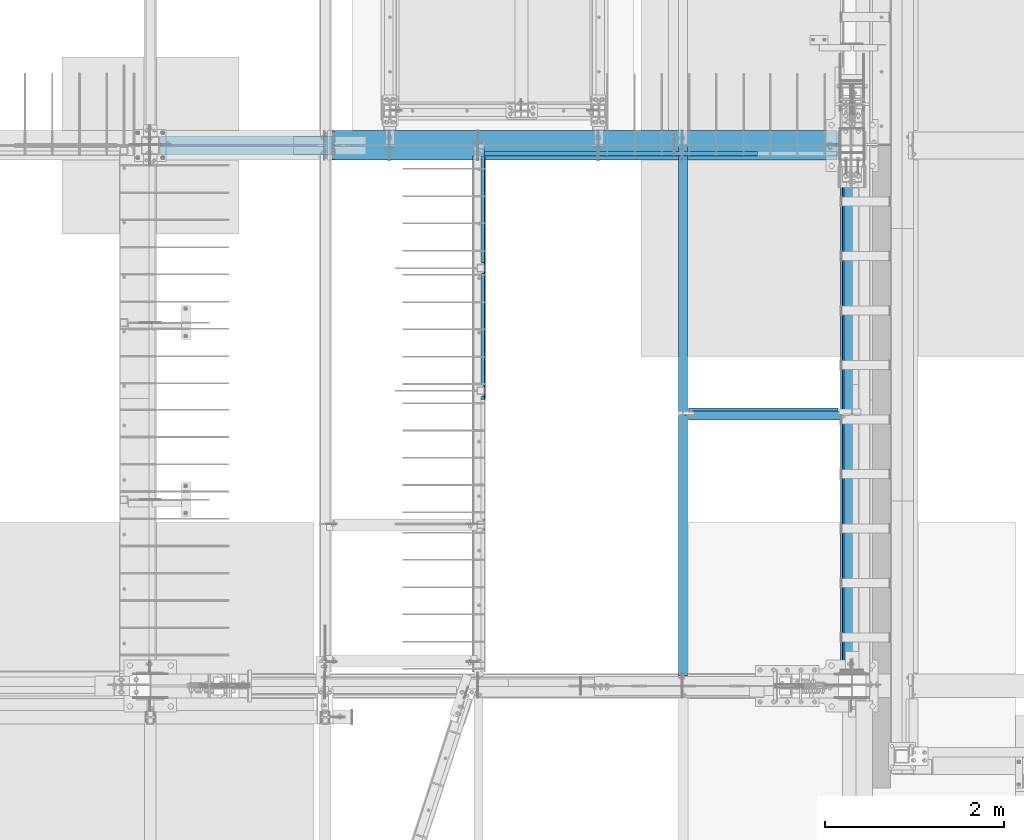
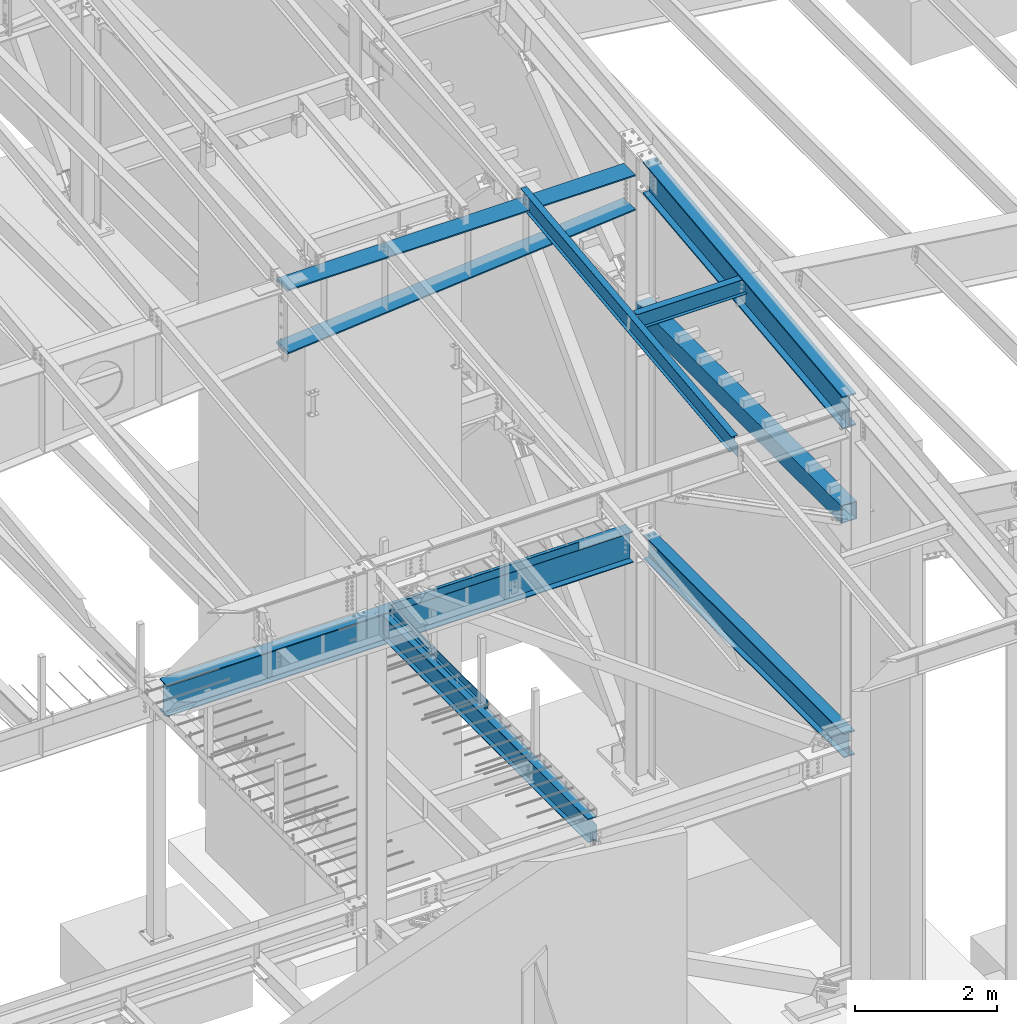
# One storey, part 720 of 1179: 11 beams, 8 elements without a shape of their own.
"""IFC2X3 building model written with IfcOpenShell, lengths in millimetres."""

import ifcopenshell
import ifcopenshell.guid

model = None  # the IFC model being written
_history = None  # IfcOwnerHistory: only IFC2X3 demands one
_inside = {}  # id of a spatial element -> (the spatial element, [elements in it])
_under = {}  # id of a project, library or spatial element -> (it, [spatial elements below it])
_declared = {}  # id of a project -> (the project, [libraries it declares])
_typed = {}  # id of a type object -> (the type object, [elements of that type])
_made_of = {}  # id of a material, layer set ... -> (it, [elements and type objects made of it])


def new_model(schema):
    """Start an empty IFC model of exactly this schema.

    Asked for "IFC4X3", IfcOpenShell would pick the latest addendum, in which some entities
    have other attributes; the version numbers below select the first issue.
    IFC2X3 requires an IfcOwnerHistory on every rooted entity: one is made here for all.
    """
    global model, _history
    if schema == "IFC4X3":
        model = ifcopenshell.file(schema_version=(4, 3, 0, 0))
    else:
        model = ifcopenshell.file(schema=schema)
    _inside.clear()
    _under.clear()
    _declared.clear()
    _typed.clear()
    _made_of.clear()
    _history = None
    if model.schema == "IFC2X3":
        org = make("IfcOrganization", Name="unknown")
        user = make(
            "IfcPersonAndOrganization",
            ThePerson=make("IfcPerson", FamilyName="unknown"),
            TheOrganization=org,
        )
        app = make(
            "IfcApplication",
            ApplicationDeveloper=org,
            Version="unknown",
            ApplicationFullName="unknown",
            ApplicationIdentifier="unknown",
        )
        _history = make(
            "IfcOwnerHistory",
            OwningUser=user,
            OwningApplication=app,
            ChangeAction="ADDED",
            CreationDate=0,
        )
    return model


def make(cls, **values):
    """One entity of the class cls with the attributes given. An attribute that is None is left unset."""
    return model.create_entity(
        cls, **{name: value for name, value in values.items() if value is not None}
    )


def rooted(cls, **values):
    """An entity with a GlobalId (a new one), such as an element, a storey or a relation."""
    return make(cls, GlobalId=ifcopenshell.guid.new(), OwnerHistory=_history, **values)


def si_unit(unit_type, name, prefix=None):
    """IfcSIUnit, for example si_unit("LENGTHUNIT", "METRE", prefix="MILLI")."""
    return make("IfcSIUnit", UnitType=unit_type, Prefix=prefix, Name=name)


def assignment(units):
    """IfcUnitAssignment: the units of a project."""
    return None if units is None else make("IfcUnitAssignment", Units=units)


def point(xyz):
    """IfcCartesianPoint."""
    return None if xyz is None else make("IfcCartesianPoint", Coordinates=xyz)


def direction(xyz):
    """IfcDirection."""
    return None if xyz is None else make("IfcDirection", DirectionRatios=xyz)


def frame(location, z_axis=None, x_axis=None):
    """IfcAxis2Placement3D, a coordinate frame: its origin and axes. An axis left out is left unset."""
    return make(
        "IfcAxis2Placement3D",
        Location=point(location),
        Axis=direction(z_axis),
        RefDirection=direction(x_axis),
    )


def origin_with_axes():
    """The frame at (0, 0, 0) with the z axis (0, 0, 1) and the x axis (1, 0, 0) written out."""
    return frame((0.0, 0.0, 0.0), z_axis=(0.0, 0.0, 1.0), x_axis=(1.0, 0.0, 0.0))


def place(relative_to, where):
    """IfcLocalPlacement: puts the frame where relative to a parent placement (None: the world)."""
    return make(
        "IfcLocalPlacement", PlacementRelTo=relative_to, RelativePlacement=where
    )


def context(
    kind, dimensions, precision=None, world=None, true_north=None, identifier=None
):
    """IfcGeometricRepresentationContext, for example the 3D "Model" context."""
    return make(
        "IfcGeometricRepresentationContext",
        ContextIdentifier=identifier,
        ContextType=kind,
        CoordinateSpaceDimension=dimensions,
        Precision=precision,
        WorldCoordinateSystem=world,
        TrueNorth=true_north,
    )


def subcontext(parent, identifier, kind, view, scale=None):
    """IfcGeometricRepresentationSubContext, for example "Body" below "Model"."""
    return make(
        "IfcGeometricRepresentationSubContext",
        ContextIdentifier=identifier,
        ContextType=kind,
        ParentContext=parent,
        TargetScale=scale,
        TargetView=view,
    )


def project(units=None, contexts=None):
    """IfcProject with its units and contexts."""
    return rooted(
        "IfcProject",
        Name="project",
        RepresentationContexts=contexts,
        UnitsInContext=assignment(units),
    )


def spatial(cls, under=None, at=None, **own):
    """A site, building, storey or space (cls), placed at a placement, below another one or the project."""
    s = rooted(cls, ObjectPlacement=at, **own)
    if under is not None:
        _under.setdefault(under.id(), (under, []))[1].append(s)
    return s


def faces_of(points, faces, orient=None, outer=None):
    """IfcFace entities. A face is a list of loops; a loop is a list of indices into points, from 0.

    orient and outer hold one flag for each loop. By default every Orientation is true, the
    first loop of a face is its IfcFaceOuterBound and the others are IfcFaceBound.
    """
    made = []
    for i, loops in enumerate(faces):
        bounds = []
        for j, loop in enumerate(loops):
            is_outer = j == 0 if outer is None else outer[i][j]
            bounds.append(
                make(
                    "IfcFaceOuterBound" if is_outer else "IfcFaceBound",
                    Bound=make("IfcPolyLoop", Polygon=[points[k] for k in loop]),
                    Orientation=True if orient is None else orient[i][j],
                )
            )
        made.append(make("IfcFace", Bounds=bounds))
    return made


def faceted_brep(points, faces, orient=None, outer=None, voids=None):
    """IfcFacetedBrep: a solid bounded by flat faces; with voids (closed shells), ...WithVoids."""
    shared = [point(p) for p in points]
    hull = make("IfcClosedShell", CfsFaces=faces_of(shared, faces, orient, outer))
    if voids is None:
        return make("IfcFacetedBrep", Outer=hull)
    return make(
        "IfcFacetedBrepWithVoids",
        Outer=hull,
        Voids=[
            make(cls, CfsFaces=faces_of(shared, fs, o, b)) for cls, fs, o, b in voids
        ],
    )


def shape(context_of_items, identifier, shape_type, items):
    """IfcShapeRepresentation: the items that make up one representation, for example the "Body"."""
    return make(
        "IfcShapeRepresentation",
        ContextOfItems=context_of_items,
        RepresentationIdentifier=identifier,
        RepresentationType=shape_type,
        Items=items,
    )


def material(Name=None, Category=None):
    """IfcMaterial."""
    return make("IfcMaterial", Name=Name, Category=Category)


def made_of(thing, what):
    """Note that an element or type object is made of a material, layer set ...; save() writes the relation."""
    if what is not None:
        _made_of.setdefault(what.id(), (what, []))[1].append(thing)
    return thing


def type_object(cls, material=None, **own):
    """A type object (cls), such as IfcWallType, which elements share."""
    return made_of(rooted(cls, **own), material)


def element(
    cls,
    number,
    at=None,
    inside=None,
    cuts=None,
    type_object=None,
    material=None,
    context=None,
    identifier="Body",
    shape_type=None,
    held_by="IfcProductDefinitionShape",
    body=None,
    shapes=None,
    **own,
):
    """One element of the class cls, such as IfcWall. Its Tag is "e" and its number.

    at: its placement. inside: the storey or other place that contains it. cuts: it is an
    opening in that element (IfcRelVoidsElement). A single representation is given by context,
    identifier, shape_type and body (its items); several are given by shapes. held_by: the class
    of the entity that holds the representations. save() writes the other relations.
    """
    e = rooted(cls, Tag="e%d" % number, ObjectPlacement=at, **own)
    if body is not None:
        shapes = [shape(context, identifier, shape_type, body)]
    if shapes is not None:
        e.Representation = make(held_by, Representations=shapes)
    if inside is not None:
        _inside.setdefault(inside.id(), (inside, []))[1].append(e)
    if cuts is not None:
        rooted(
            "IfcRelVoidsElement", RelatingBuildingElement=cuts, RelatedOpeningElement=e
        )
    if type_object is not None:
        _typed.setdefault(type_object.id(), (type_object, []))[1].append(e)
    return made_of(e, material)


def aggregate(whole, parts):
    """IfcRelAggregates: a whole, such as a stair, and the parts it consists of."""
    return rooted("IfcRelAggregates", RelatingObject=whole, RelatedObjects=parts)


def save(model, path):
    """Write the relations noted so far, then the file.

    IfcRelAggregates (storeys below a building ...), IfcRelContainedInSpatialStructure (elements
    in a storey), IfcRelDefinesByType, IfcRelAssociatesMaterial and IfcRelDeclares: one each for
    every whole, place, type object, material and project.
    """
    for whole, parts in _under.values():
        aggregate(whole, parts)
    for where, things in _inside.values():
        rooted(
            "IfcRelContainedInSpatialStructure",
            RelatedElements=things,
            RelatingStructure=where,
        )
    for kind, things in _typed.values():
        rooted("IfcRelDefinesByType", RelatedObjects=things, RelatingType=kind)
    for what, things in _made_of.values():
        rooted("IfcRelAssociatesMaterial", RelatedObjects=things, RelatingMaterial=what)
    for by, libraries in _declared.values():
        rooted("IfcRelDeclares", RelatingContext=by, RelatedDefinitions=libraries)
    model.write(path)


model = new_model("IFC2X3")

# Units and contexts
model_context = context("Model", 3, precision=1e-05, world=origin_with_axes())
body_context = subcontext(model_context, "Body", "Model", "MODEL_VIEW")
ifc_project = project(units=[si_unit("LENGTHUNIT", "METRE", prefix="MILLI"), si_unit("AREAUNIT", "SQUARE_METRE"), si_unit("VOLUMEUNIT", "CUBIC_METRE"), si_unit("MASSUNIT", "GRAM", prefix="KILO"), si_unit("TIMEUNIT", "SECOND"), si_unit("PLANEANGLEUNIT", "RADIAN"), si_unit("SOLIDANGLEUNIT", "STERADIAN"), si_unit("THERMODYNAMICTEMPERATUREUNIT", "DEGREE_CELSIUS"), si_unit("LUMINOUSINTENSITYUNIT", "LUMEN")], contexts=[model_context])

# Site, building, storey
site_placement = place(None, origin_with_axes())
site = spatial("IfcSite", under=ifc_project, at=site_placement, CompositionType="ELEMENT")
building_placement = place(site_placement, origin_with_axes())
building = spatial("IfcBuilding", under=site, at=building_placement, Name="Undefined", CompositionType="ELEMENT")
storey_placement = place(building_placement, origin_with_axes())
storey = spatial("IfcBuildingStorey", under=building, at=storey_placement, Name="Undefined", CompositionType="ELEMENT", Elevation=0.0)

# Assembly, beam
assembly_1_placement = place(storey_placement, origin_with_axes())
assembly_1 = element("IfcElementAssembly", 1, at=assembly_1_placement, inside=storey, Name="BEAM", AssemblyPlace="NOTDEFINED", PredefinedType="RIGID_FRAME")
ifc_material_1 = material(Name="STEEL/A36")
beam_type_1 = type_object("IfcBeamType", PredefinedType="NOTDEFINED")
beam_1_placement = place(assembly_1_placement, frame((21723.35, 11366.5, 4235.45000610352), z_axis=(1.0, 0.0, 0.0), x_axis=(0.0, 0.0, -1.0)))
beam_1 = element("IfcBeam", 2, at=beam_1_placement, type_object=beam_type_1, material=ifc_material_1, Name="BENT_PLATE", context=body_context, shape_type="Brep", body=[
    faceted_brep([(0.0, -3.17499999999927, -1524.0), (6.00266503170133e-10, -3.17499999922438, 1524.00000000052), (6.00266503170133e-10, 3.17500000077416, 1524.00000000052), (0.0, 3.17499999999927, -1524.0), (127.000006103516, 3.17499999999927, 1524.0), (127.000006103516, 3.17499999999927, -1524.0), (133.350006103517, -3.17499999999927, -1524.0), (133.350006103517, -3.17499999999927, 1524.0), (127.000006103516, 47.6249992370613, 1524.0), (127.000006103516, 47.6249992370613, -1524.0), (133.350006103517, 47.6249992370613, 1524.0), (133.350006103517, 47.6249992370613, -1524.0)], [[[0, 1, 2, 3]], [[3, 2, 4, 5]], [[1, 0, 6, 7]], [[5, 4, 8, 9]], [[4, 2, 1, 7, 10, 8]], [[7, 6, 11, 10]], [[6, 0, 3, 5, 9, 11]], [[10, 11, 9, 8]]]),
])

assembly_2_placement = place(storey_placement, origin_with_axes())
assembly_2 = element("IfcElementAssembly", 3, at=assembly_2_placement, inside=storey, Name="BEAM", AssemblyPlace="NOTDEFINED", PredefinedType="RIGID_FRAME")
ifc_material_2 = material(Name="STEEL/A992")
beam_type_2 = type_object("IfcBeamType", Name="W12X14", PredefinedType="NOTDEFINED")
beam_2_placement = place(assembly_2_placement, frame((22415.5000835348, 8475.14317923319, 10052.7877808976), z_axis=(0.0, -0.112284087038017, 0.993676146336441), x_axis=(0.999999999988899, -4.71199999952473e-06, 0.0)))
beam_2 = element("IfcBeam", 4, at=beam_2_placement, type_object=beam_type_2, material=ifc_material_2, Name="BEAM", ObjectType="W12X14", context=body_context, shape_type="Brep", body=[
    faceted_brep([(1770.85649904564, -50.7999999986041, 150.812499999789), (1770.85649904565, -50.7999999986059, 144.46249999979), (1770.85649904561, -2.381249998567, 144.462499999787), (1770.8564990458, -2.38124999857428, 125.412499806802), (1770.85649904581, 2.38167736519972, 125.412499806804), (1770.85649904561, 2.38125000143555, 144.462499999785), (1770.85649904557, 50.8000000014763, 144.462499999781), (1770.85649904556, 50.8000000014781, 150.81249999978), (1771.82322896839, -2.3812499985761, 120.552420288775), (1771.8232289684, 2.38163594190701, 120.552420288775), (1774.57624286887, -2.38124999857428, 116.432243820635), (1774.57624286888, 2.38160097677792, 116.432243820636), (1778.69641933703, -2.38124999857246, 113.679229920166), (1778.69641933704, 2.38157779293761, 113.679229920168), (1783.55649885508, -2.38124999857064, 112.712499997577), (1783.55649885509, 2.38156991991491, 112.712499997579), (1872.45624059635, -2.3812499984997, 112.712499997355), (1872.45621725151, 2.38125000150285, 112.712499997353), (62.7059974723888, -50.7999999999302, 150.81249999994), (62.7059974723124, 50.8000000001521, 150.812499999931), (62.7059974723197, 50.8000000001484, 144.462499999931), (62.7059974723561, 2.3812500001095, 144.462499999934), (62.7059974721487, 2.38161408837368, 138.112499807496), (62.7059974721342, -2.38124999989668, 138.112499807496), (62.7059974723597, -2.38124999989304, 144.462499999938), (62.7059974723961, -50.799999999932, 144.462499999941), (61.7392675495539, 2.38157202631191, 133.252420289446), (61.7392675495394, -2.3812499998985, 133.252420289446), (58.9862536490546, 2.38153636781681, 129.132243821286), (58.9862536490436, -2.38124999990396, 129.132243821286), (54.8660771808754, 2.38151254157128, 126.379229920809), (54.8660771808609, -2.3812499999076, 126.379229920805), (50.0059976628036, 2.38150417490215, 125.412499998221), (50.005997662789, -2.38124999991123, 125.412499998223), (15.0812242587599, 2.38125000006403, 125.412499998332), (15.0812476035971, -2.38124999993852, 125.412499998332), (15.0810853273215, 2.38124999996217, -125.412500001446), (15.0811086721551, -2.38125000003856, -125.412500001445), (50.0059976626144, 2.37934495275113, -125.41250000147), (50.0059976626035, -2.3812500000131, -125.412500001472), (54.8660771806644, 2.3793365119891, -126.379229924058), (54.8660771806535, -2.38125000000946, -126.379229924061), (58.9862536488217, 2.379312566929, -129.132243824528), (58.9862536488108, -2.38125000000764, -129.13224382453), (61.7392675493029, 2.37927676298568, -133.252420292667), (61.7392675492883, -2.38125000000764, -133.252420292667), (62.7059974718941, 2.37923455098462, -138.112499810695), (62.7059974718795, -2.38125000000946, -138.112499810699), (62.7059974720578, 50.800000000032, -144.462499999951), (62.7059974720978, 2.37627512105973, -144.462499999945), (1732.75606310386, 2.38086597553229, -144.462500000094), (1732.75582577042, 50.800000001329, -144.462500000096), (62.7059974720687, 50.8000000000284, -150.812499999949), (1732.75582225317, 50.8000000013253, -150.812500000095), (1732.7560595773, 2.38425295571142, -150.812500000089), (1872.45607480283, 2.38125000139917, -144.462500000105), (1872.4560712675, 2.38493773793743, -150.812500000102), (1872.45633196957, -50.7999999986459, -150.812500000098), (62.7059974721487, -50.800000000052, -150.81249999994), (1872.45633548682, -50.7999999986441, -144.4625000001), (62.7059974721378, -50.800000000052, -144.462499999941), (62.7059974720978, -2.38125000001128, -144.462499999945), (1872.45609814766, -2.3812499986052, -144.462500000103)], [[[0, 1, 2, 3, 4, 5, 6, 7]], [[8, 9, 4, 3]], [[10, 11, 9, 8]], [[12, 13, 11, 10]], [[14, 15, 13, 12]], [[16, 17, 15, 14]], [[18, 19, 20, 21, 22, 23, 24, 25]], [[23, 22, 26, 27]], [[27, 26, 28, 29]], [[29, 28, 30, 31]], [[31, 30, 32, 33]], [[33, 32, 34, 35]], [[35, 34, 36, 37]], [[37, 36, 38, 39]], [[39, 38, 40, 41]], [[41, 40, 42, 43]], [[43, 42, 44, 45]], [[45, 44, 46, 47]], [[48, 49, 50, 51]], [[52, 48, 51, 53]], [[50, 54, 53, 51]], [[55, 56, 54, 50]], [[57, 58, 52, 53, 54, 56]], [[57, 59, 60, 58]], [[47, 46, 49, 48, 52, 58, 60, 61]], [[59, 62, 61, 60]], [[12, 10, 8, 3, 2, 24, 23, 27, 29, 31, 33, 35, 37, 39, 41, 43, 45, 47, 61, 62, 16, 14]], [[25, 24, 2, 1]], [[18, 25, 1, 0]], [[19, 18, 0, 7]], [[20, 19, 7, 6]], [[21, 20, 6, 5]], [[55, 50, 49, 46, 44, 42, 40, 38, 36, 34, 32, 30, 28, 26, 22, 21, 5, 4, 9, 11, 13, 15, 17]], [[62, 59, 57, 56, 55, 17, 16]]]),
])
aggregate(assembly_2, [beam_2])

assembly_3_placement = place(storey_placement, origin_with_axes())
assembly_3 = element("IfcElementAssembly", 5, at=assembly_3_placement, inside=storey, Name="BEAM", AssemblyPlace="NOTDEFINED", PredefinedType="RIGID_FRAME")
beam_3_placement = place(assembly_3_placement, frame((22415.5, 5452.5431792468, 9711.23798851528), z_axis=(0.0, -0.112284087038017, 0.993676146336441), x_axis=(0.0, 0.993676146336441, 0.112284087038017)))
beam_3 = element("IfcBeam", 6, at=beam_3_placement, type_object=beam_type_2, material=ifc_material_2, Name="BEAM", ObjectType="W12X14", context=body_context, shape_type="Brep", body=[
    faceted_brep([(5871.37503272929, -2.38124999999854, -144.462500002917), (5871.37503272929, -50.7999999999993, -144.462500002917), (5870.65749114864, -50.7999999999993, -150.812500002912), (5870.65749114864, 50.7999999999993, -150.812500002912), (5871.37503272929, 50.7999999999993, -144.462500002917), (5871.37503272928, 2.38124783346939, -144.462500002968), (5874.19845246322, 2.38122628119891, -119.476191482236), (5874.19845246322, -2.38124999999854, -119.476191482236), (5875.70477851863, 2.38122688934163, -114.755394783042), (5875.70477851863, -2.38124999999854, -114.755394783042), (5878.90301301472, 2.38122737693629, -110.970393360541), (5878.90301301472, -2.38124999999854, -110.970393360541), (5883.30625374162, 2.38122766974266, -108.697419370077), (5883.30625374162, -2.38124999999854, -108.697419370077), (5888.24414721426, 2.38122772319184, -108.282512497075), (5888.24414721426, -2.38124999999854, -108.282512497075), (6045.98095926941, -2.38124999999854, -126.106563095373), (6045.98095929506, 2.38124999999854, -126.10656309827), (6076.55490468175, -50.7999999999993, 144.462499996846), (6077.27244626239, -50.7999999999993, 150.812499996842), (114.228614327105, -50.7999999999993, 150.812499999873), (113.511072746461, -50.7999999999993, 144.462499999876), (6077.27244626239, 50.7999999999993, 150.812499996842), (114.228614327105, 50.7999999999993, 150.812499999873), (6076.55490468175, 50.7999999999993, 144.462499996846), (113.511072746461, 50.7999999999993, 144.462499999876), (6076.55490468175, 2.38124999999854, 144.462499996846), (113.511072746461, 2.38124999999854, 144.462499999876), (136.689207968453, 50.7999999999993, -144.462500000005), (136.689207968449, 50.7999999999993, -150.8125), (136.689200027815, 2.38132415300061, -150.812500000002), (136.689200027785, 2.38117582134146, -144.462500001737), (-15.7107912112788, 2.38134914656257, -150.812499999922), (-14.9932496306401, 2.38124999999854, -144.462499999927), (136.689191329944, -50.7999999999993, -144.462500000003), (136.689199270568, -2.38124999999854, -144.462500000005), (136.689199270599, -2.38117588245223, -150.8125), (136.689191329941, -50.7999999999993, -150.8125), (-14.9932496306401, -2.38124999999854, -144.462499999927), (-15.7107912112788, -2.38115088886843, -150.812499999922), (-14.7278431263294, -2.38124999999854, -142.113742314172), (10.9745586429563, -2.38124999999854, 85.3438094690136), (10.9745586429563, 2.38124999999854, 85.3438094690136), (-14.7278305511045, 2.38124999999854, -142.113631027696), (93.0025247126168, -2.38124999999854, 76.0747580626012), (93.0025247126168, 2.38124999999854, 76.0747580626012), (97.9404181857699, -2.38124999999854, 76.4896649350048), (97.9404181857699, 2.38124999999854, 76.4896649350048), (102.343658913291, -2.38124999999854, 78.7626389252728), (102.343658913291, 2.38124999999854, 78.7626389252728), (105.541893409889, -2.38124999999854, 82.5476403479479), (105.541893409889, 2.38124999999854, 82.5476403479479), (107.048219465527, -2.38124999999854, 87.2684370475545), (107.048219465527, 2.38124999999854, 87.2684370475545), (113.511072746461, -2.38124999999854, 144.462499999876), (6076.55490468175, -2.38124999999854, 144.462499996846)], [[[0, 1, 2, 3, 4, 5, 6, 7]], [[7, 6, 8, 9]], [[9, 8, 10, 11]], [[11, 10, 12, 13]], [[13, 12, 14, 15]], [[16, 15, 14, 17]], [[18, 19, 20, 21]], [[19, 22, 23, 20]], [[22, 24, 25, 23]], [[24, 26, 27, 25]], [[28, 29, 30, 31]], [[31, 30, 32, 33]], [[34, 35, 36, 37]], [[38, 39, 36, 35]], [[40, 41, 42, 43, 33, 32, 39, 38]], [[44, 45, 42, 41]], [[46, 47, 45, 44]], [[48, 49, 47, 46]], [[50, 51, 49, 48]], [[52, 53, 51, 50]], [[20, 23, 25, 27, 53, 52, 54, 21]], [[55, 18, 21, 54]], [[26, 24, 22, 19, 18, 55, 16, 17]], [[12, 10, 8, 6, 5, 31, 33, 43, 42, 45, 47, 49, 51, 53, 27, 26, 17, 14]], [[28, 31, 5, 4]], [[29, 28, 4, 3]], [[37, 36, 39, 32, 30, 29, 3, 2]], [[34, 37, 2, 1]], [[35, 34, 1, 0]], [[55, 54, 52, 50, 48, 46, 44, 41, 40, 38, 35, 0, 7, 9, 11, 13, 15, 16]]]),
])
aggregate(assembly_3, [beam_3])

# Assembly, beams
assembly_4_placement = place(storey_placement, origin_with_axes())
assembly_4 = element("IfcElementAssembly", 7, at=assembly_4_placement, inside=storey, Name="BEAM", AssemblyPlace="NOTDEFINED", PredefinedType="RIGID_FRAME")
beam_type_3 = type_object("IfcBeamType", Name="W16X31", PredefinedType="NOTDEFINED")
beam_4_placement = place(assembly_4_placement, frame((20129.5, 5435.6, 3900.4875), z_axis=(0.0, 0.0, 1.0), x_axis=(0.0, 1.0, 0.0)))
beam_4 = element("IfcBeam", 8, at=beam_4_placement, type_object=beam_type_3, material=ifc_material_2, Name="BEAM", ObjectType="W16X31", context=body_context, shape_type="Brep", body=[
    faceted_brep([(19.84375, -3.17499999999927, -141.2875), (19.84375, 3.17499999999927, -141.2875), (142.081250190735, 3.17517002077875, -141.2875), (142.081250190735, -3.17499999999927, -141.2875), (146.94132970878, 3.17517064521599, -142.254229922588), (146.94132970878, -3.17499999999927, -142.254229922588), (151.061506176934, 3.17517242088434, -145.007243823066), (151.061506176934, -3.17499999999927, -145.007243823066), (153.814520077412, 3.17517507744924, -149.12742029122), (153.814520077412, -3.17499999999927, -149.12742029122), (154.78125, -3.17499999999927, -153.987499809266), (154.78125, 3.17517821047295, -153.987499809266), (154.780750000001, 3.17549991607666, -190.5), (154.780750000001, 3.17549991607666, -201.6125), (154.78125, -69.8499999999985, -201.6125), (154.78125, -69.8499999999985, -190.5), (154.78125, -3.17499999999927, -190.5), (5900.73750167641, 69.8499999985015, -190.5), (5900.73750167641, 69.8499999985015, -201.6125), (154.780750000001, 69.8499999999985, -201.6125), (154.780750000001, 69.8499999999985, -190.5), (5900.73750007622, 3.17499999850133, -190.5), (5900.73749999986, 3.17549991607666, -201.6125), (6027.73750007621, 3.17499999846859, -190.5), (6027.7375, 3.17549991607666, -201.6125), (5927.72500167648, 69.8499999984942, 190.5), (5927.72500167647, 3.17499999849406, 190.5), (154.78125, 3.17499999999927, 190.5), (154.78125, 69.8499999999985, 190.5), (142.081250190735, -3.17499999999927, 163.5125), (142.081250190735, 3.17497498411103, 163.5125), (19.84375, 3.17499999999927, 163.5125), (19.84375, -3.17499999999927, 163.5125), (146.94132970878, -3.17499999999927, 164.479229922588), (146.94132970878, 3.17497436273698, 164.479229922588), (151.061506176934, -3.17499999999927, 167.232243823066), (151.061506176934, 3.17497259321317, 167.232243823066), (153.814520077412, -3.17499999999927, 171.352420291219), (153.814520077412, 3.17496994493558, 171.352420291219), (154.78125, -3.17499999999927, 176.212499809265), (154.78125, 3.17496682107958, 176.212499809265), (5927.72500167645, -69.8500000015056, 201.6125), (5927.72500167648, 69.8499999984942, 201.6125), (154.78125, 69.8499999999985, 201.6125), (154.78125, -69.8499999999985, 201.6125), (5927.72500167645, -69.8500000015056, 190.5), (154.78125, -69.8499999999985, 190.5), (5927.72500167647, -3.1750000015054, 190.5), (154.78125, -3.17499999999927, 190.5), (5927.72500167647, -3.1750000015054, 182.562499809265), (5927.72500167647, 3.17499999849406, 182.562499809265), (5928.69173159905, -3.1750000015054, 177.702420291219), (5928.69173159905, 3.17499999849406, 177.702420291219), (5931.44474549953, -3.17500000150721, 173.582243823066), (5931.44474549953, 3.17499999849315, 173.582243823066), (5935.56492196769, -3.17500000150812, 170.829229922588), (5935.56492196769, 3.17499999849224, 170.829229922588), (5940.42500148573, -3.17500000150903, 169.8625), (5940.42500148573, 3.17499999849133, 169.8625), (6027.73749992381, -3.17500000153177, 169.8625), (6027.73750007621, 3.17499999846859, 169.8625), (6027.73749992381, -3.17500000153177, -190.5), (6027.73749832361, -69.850000001531, -190.5), (6027.73749832361, -69.850000001531, -201.6125)], [[[0, 1, 2, 3]], [[3, 2, 4, 5]], [[5, 4, 6, 7]], [[7, 6, 8, 9]], [[10, 11, 12, 13, 14, 15, 16]], [[9, 8, 11, 10]], [[17, 18, 19, 20]], [[21, 22, 18, 17]], [[23, 24, 22, 21]], [[25, 26, 27, 28]], [[29, 30, 31, 32]], [[33, 34, 30, 29]], [[35, 36, 34, 33]], [[37, 38, 36, 35]], [[39, 40, 38, 37]], [[41, 42, 43, 44]], [[45, 41, 44, 46]], [[47, 45, 46, 48]], [[44, 43, 28, 27, 40, 39, 48, 46]], [[42, 25, 28, 43]], [[41, 45, 47, 49, 50, 26, 25, 42]], [[51, 52, 50, 49]], [[53, 54, 52, 51]], [[55, 56, 54, 53]], [[57, 58, 56, 55]], [[59, 60, 58, 57]], [[61, 62, 63, 24, 23, 60, 59]], [[62, 61, 16, 15]], [[63, 62, 15, 14]], [[19, 18, 22, 24, 63, 14, 13]], [[20, 19, 13, 12]], [[21, 17, 20, 12]], [[6, 4, 2, 1, 31, 30, 34, 36, 38, 40, 27, 26, 50, 52, 54, 56, 58, 60, 23, 21, 12, 11, 8]], [[32, 31, 1, 0]], [[61, 59, 57, 55, 53, 51, 49, 47, 48, 39, 37, 35, 33, 29, 32, 0, 3, 5, 7, 9, 10, 16]]]),
])
beam_type_4 = type_object("IfcBeamType", PredefinedType="NOTDEFINED")
beam_5_placement = place(assembly_4_placement, frame((20202.525, 10000.45625, 4235.45000610352), z_axis=(0.0, 1.0, 0.0), x_axis=(0.0, 0.0, -1.0)))
beam_5 = element("IfcBeam", 9, at=beam_5_placement, type_object=beam_type_4, material=ifc_material_1, Name="BENT_PLATE", context=body_context, shape_type="Brep", body=[
    faceted_brep([(133.350006103517, 47.6249992370613, -1325.5625), (127.000006103516, 47.6249992370613, -1325.5625), (127.000006103516, 3.17499999999927, -1325.5625), (133.350006103517, 3.17499999999927, -1325.5625), (133.350006103517, 3.17499999999927, -1198.5625), (127.000006103516, 3.17499999999927, -1198.5625), (127.000006103516, 47.6249992370613, -1198.5625), (133.350006103517, 47.6249992370613, -1198.5625), (127.000006103516, 3.17499999999927, 1362.075), (127.000006103516, 47.6249992370613, 1362.075), (127.000006103516, 47.6249992370613, 173.037499999995), (127.000006103516, 3.17499999999927, 173.037499999995), (0.0, 3.17499999999927, 46.0374999999949), (0.0, 3.17499999999927, -1198.5625), (0.0, 3.17499999999927, -1325.5625), (0.0, 3.17499999999927, -1362.075), (0.0, -3.17499999999927, -1362.075), (0.0, -3.17499999999927, 1362.075), (0.0, 3.17499999999927, 1362.075), (0.0, 3.17499999999927, 173.037499999995), (133.350006103517, -3.17499999999927, -1362.075), (127.000006103516, 3.17499999999927, -1362.075), (127.000006103516, 47.6249992370613, -1362.075), (133.350006103517, 47.6249992370613, -1362.075), (133.350006103517, -3.17499999999927, 1362.075), (133.350006103517, 47.6249992370613, 1362.075), (133.350006103517, 47.6249992370613, 173.037499999995), (133.350006103517, 3.17499999999927, 173.037499999995), (133.350006103517, 3.17499999999927, 46.0374999999949), (127.000006103516, 3.17499999999927, 46.0374999999949), (133.350006103517, 47.6249992370613, 46.0374999999949), (127.000006103516, 47.6249992370613, 46.0374999999949)], [[[0, 1, 2, 3]], [[4, 5, 6, 7]], [[3, 2, 5, 4]], [[8, 9, 10, 11]], [[12, 13, 14, 15, 16, 17, 18, 19]], [[20, 16, 15, 21, 22, 23]], [[17, 16, 20, 24]], [[8, 18, 17, 24, 25, 9]], [[9, 25, 26, 10]], [[27, 11, 10, 26]], [[28, 29, 11, 27]], [[30, 31, 29, 28]], [[31, 30, 7, 6]], [[29, 31, 6, 5]], [[15, 14, 13, 12, 19, 18, 8, 11, 29, 5, 2, 21]], [[22, 21, 2, 1]], [[23, 22, 1, 0]], [[30, 28, 27, 26, 25, 24, 20, 23, 0, 3, 4, 7]]]),
])
aggregate(assembly_4, [beam_5, beam_4])

assembly_5_placement = place(storey_placement, origin_with_axes())
assembly_5 = element("IfcElementAssembly", 10, at=assembly_5_placement, inside=storey, Name="RAFTER BEAM", AssemblyPlace="NOTDEFINED", PredefinedType="RIGID_FRAME")
beam_type_5 = type_object("IfcBeamType", PredefinedType="NOTDEFINED")
beam_6_placement = place(assembly_5_placement, frame((18466.7699127408, 11480.8093353647, 9156.76376523318), z_axis=(0.0, 1.0, 0.0), x_axis=(0.996183710890709, 0.0, 0.0872812359904244)))
beam_6 = element("IfcBeam", 11, at=beam_6_placement, type_object=beam_type_5, material=ifc_material_1, Name="PLATE", context=body_context, shape_type="Brep", body=[
    faceted_brep([(50.043578213099, -11.1125244904742, 165.1), (23.5500482208263, 11.1125000000075, 165.1), (23.5500482208263, 11.1125000000075, -165.1), (50.0435782131026, -11.1125000000075, -165.1), (5693.8669426845, -11.1124999999474, 165.1), (5693.8669426845, -11.1124999999474, -165.1), (5691.91968591988, 11.1125000000657, -165.1), (5691.91968591988, 11.1125000000657, 165.1)], [[[0, 1, 2, 3]], [[4, 5, 6, 7]], [[5, 4, 0, 3]], [[6, 5, 3, 2]], [[7, 6, 2, 1]], [[4, 7, 1, 0]]]),
])
beam_7_placement = place(assembly_5_placement, frame((18465.8, 11480.8093353614, 10240.98385672), z_axis=(0.0, -1.0, 0.0), x_axis=(1.0, 0.0, 0.0)))
beam_7 = element("IfcBeam", 12, at=beam_7_placement, type_object=beam_type_5, material=ifc_material_1, Name="PLATE", context=body_context, shape_type="Brep", body=[
    faceted_brep([(47.6250003814685, 11.1125003814705, 165.1), (47.6250003814685, 11.1124999999993, -165.1), (25.3999999999987, -11.1124999999993, -165.1), (25.3999999999987, -11.1124999999993, 165.1), (5672.13750008408, -11.1124999999993, 165.1), (5672.13750008408, -11.1124999999993, -165.1), (5672.13750008408, 11.1124999999993, -165.1), (5672.13750008408, 11.1124999999993, 165.1)], [[[0, 1, 2, 3]], [[4, 5, 6, 7]], [[4, 7, 0, 3]], [[5, 4, 3, 2]], [[6, 5, 2, 1]], [[7, 6, 1, 0]]]),
])
aggregate(assembly_5, [beam_6, beam_7])

# Assembly, beam
assembly_6_placement = place(storey_placement, origin_with_axes())
assembly_6 = element("IfcElementAssembly", 13, at=assembly_6_placement, inside=storey, Name="BEAM", AssemblyPlace="NOTDEFINED", PredefinedType="RIGID_FRAME")
beam_type_6 = type_object("IfcBeamType", Name="W16X57", PredefinedType="NOTDEFINED")
beam_8_placement = place(assembly_6_placement, frame((24307.8, 5435.6, 3894.1375), z_axis=(0.0, 0.0, 1.0), x_axis=(0.0, 1.0, 0.0)))
beam_8 = element("IfcBeam", 14, at=beam_8_placement, type_object=beam_type_6, material=ifc_material_2, Name="BEAM", ObjectType="W16X57", context=body_context, shape_type="Brep", body=[
    faceted_brep([(169.8625, -90.4874999999993, -207.9625), (169.8625, 90.4874999999993, -207.9625), (5797.55, 90.4874999999993, -207.9625), (5797.55, -90.4874999999993, -207.9625), (169.8625, -90.4874999999993, -190.5), (169.8625, -5.55625000000146, -190.5), (169.8625, -5.55625000000146, 190.5), (169.8625, -90.4874999999993, 190.5), (169.8625, -90.4874999999993, 207.9625), (169.8625, 90.4874999999993, 207.9625), (169.8625, 90.4874999999993, 190.5), (169.8625, 5.55625000000146, 190.5), (169.8625, 5.55625000000146, -190.5), (169.8625, 90.4874999999993, -190.5), (5797.55, -90.4874999999993, -190.5), (5797.55, -5.55625000000146, -190.5), (5797.55, -5.55625000000146, 190.5), (5797.55, -90.4874999999993, 190.5), (5797.55, -90.4874999999993, 207.9625), (5797.55, 90.4874999999993, 207.9625), (5797.55, 90.4874999999993, 190.5), (5797.55, 5.55625000000146, 190.5), (5797.55, 5.55625000000146, 157.902500178103), (5797.55, 5.55625000000146, -148.377499821999), (5797.55, 5.55625000000146, -190.5), (5797.55, 90.4874999999993, -190.5)], [[[0, 1, 2, 3]], [[0, 4, 5, 6, 7, 8, 9, 10, 11, 12, 13, 1]], [[5, 4, 14, 15]], [[6, 5, 15, 16]], [[7, 6, 16, 17]], [[8, 7, 17, 18]], [[9, 8, 18, 19]], [[10, 9, 19, 20]], [[11, 10, 20, 21]], [[12, 11, 21, 22, 23, 24]], [[13, 12, 24, 25]], [[1, 13, 25, 2]], [[24, 23, 22, 21, 20, 19, 18, 17, 16, 15, 14, 3, 2, 25]], [[4, 0, 3, 14]]]),
])
aggregate(assembly_6, [beam_8])

assembly_7_placement = place(storey_placement, origin_with_axes())
assembly_7 = element("IfcElementAssembly", 15, at=assembly_7_placement, inside=storey, Name="BEAM", AssemblyPlace="NOTDEFINED", PredefinedType="RIGID_FRAME")
beam_type_7 = type_object("IfcBeamType", Name="W21X93", PredefinedType="NOTDEFINED")
beam_9_placement = place(assembly_7_placement, frame((24307.8, 5466.44675635096, 9588.19603969819), z_axis=(0.0, -0.112284087038017, 0.993676146336441), x_axis=(0.0, 0.993676146336441, 0.112284087038017)))
beam_9 = element("IfcBeam", 16, at=beam_9_placement, type_object=beam_type_7, material=ifc_material_2, Name="BEAM", ObjectType="W21X93", context=body_context, shape_type="Brep", body=[
    faceted_brep([(108.866780282811, -106.362499999999, -274.63749999993), (108.866780282811, 106.362499999999, -274.63749999993), (5761.18622133681, 106.362499999999, -274.6375000028), (5761.18622133681, -106.362499999999, -274.6375000028), (111.557561210208, -106.362499999999, -250.824999999943), (111.557561210208, -7.14374999999927, -250.824999999943), (168.243346080721, -7.14374999999927, 250.824999999799), (168.243346080721, -106.362499999999, 250.824999999799), (170.93412700812, -106.362499999999, 274.637499999788), (170.93412700812, 106.362499999999, 274.637499999788), (168.243346080721, 106.362499999999, 250.824999999799), (168.243346080721, 7.14374999999927, 250.824999999799), (111.557561210208, 7.14374999999927, -250.824999999943), (111.557561210208, 106.362499999999, -250.824999999943), (5763.87700226421, -106.362499999999, -250.825000002811), (5763.87700226421, -7.14374999999927, -250.825000002811), (5820.56278713472, -7.14374999999927, 250.824999996928), (5820.56278713472, -106.362499999999, 250.824999996928), (5823.25356806212, -106.362499999999, 274.637499996918), (5823.25356806212, 106.362499999999, 274.637499996918), (5820.56278713472, 106.362499999999, 250.824999996928), (5820.56278713472, 7.14374999999927, 250.824999996928), (5814.53171906232, 7.14374999999927, 197.452089920271), (5769.87796061389, 7.14374999999927, -197.718550775884), (5763.87700226421, 7.14374999999927, -250.825000002811), (5763.87700226421, 106.362499999999, -250.825000002811)], [[[0, 1, 2, 3]], [[0, 4, 5, 6, 7, 8, 9, 10, 11, 12, 13, 1]], [[5, 4, 14, 15]], [[6, 5, 15, 16]], [[7, 6, 16, 17]], [[8, 7, 17, 18]], [[9, 8, 18, 19]], [[10, 9, 19, 20]], [[11, 10, 20, 21]], [[12, 11, 21, 22, 23, 24]], [[13, 12, 24, 25]], [[1, 13, 25, 2]], [[24, 23, 22, 21, 20, 19, 18, 17, 16, 15, 14, 3, 2, 25]], [[4, 0, 3, 14]]]),
])
aggregate(assembly_7, [beam_9])

# Beam
beam_type_8 = type_object("IfcBeamType", Name="W21X62", PredefinedType="NOTDEFINED")
beam_10_placement = place(assembly_1_placement, frame((16459.2, 11480.8, 3835.4), z_axis=(0.0, 0.0, 1.0), x_axis=(1.0, 0.0, 0.0)))
beam_10 = element("IfcBeam", 17, at=beam_10_placement, type_object=beam_type_8, material=ifc_material_2, Name="BEAM", ObjectType="W21X62", context=body_context, shape_type="Brep", body=[
    faceted_brep([(114.299999999999, -104.775, -250.825), (114.299999999999, -104.775, -266.7), (7678.73749918356, -104.775, -266.7), (7678.73749918356, -104.775, -250.825), (114.299999999999, -4.76250000000073, -250.825), (7678.73749918356, -4.76250000000073, -250.825), (114.299999999999, -4.76250000000073, 250.825), (7678.73749918356, -4.76250000000073, 250.825), (114.299999999999, -104.775, 250.825), (7678.73749918356, -104.775, 250.825), (114.299999999999, -104.775, 266.7), (7678.73749918356, -104.775, 266.7), (114.299999999999, 104.775, 266.7), (7678.73749918356, 104.775, 266.7), (114.299999999999, 104.775, 250.825), (7678.73749918356, 104.775, 250.825), (114.299999999999, 4.76250000000073, 250.825), (7678.73749918356, 4.76250000000073, 250.825), (114.299999999999, 4.76250000000073, -250.825), (7678.73749918356, 4.76250000000073, -250.825), (114.299999999999, 104.775, -250.825), (7678.73749918356, 104.775, -250.825), (114.299999999999, 104.775, -266.7), (7678.73749918356, 104.775, -266.7)], [[[0, 1, 2, 3]], [[4, 0, 3, 5]], [[6, 4, 5, 7]], [[8, 6, 7, 9]], [[10, 8, 9, 11]], [[12, 10, 11, 13]], [[14, 12, 13, 15]], [[16, 14, 15, 17]], [[18, 16, 17, 19]], [[20, 18, 19, 21]], [[1, 0, 4, 6, 8, 10, 12, 14, 16, 18, 20, 22]], [[1, 22, 23, 2]], [[19, 17, 15, 13, 11, 9, 7, 5, 3, 2, 23, 21]], [[22, 20, 21, 23]]]),
])

aggregate(assembly_1, [beam_1, beam_10])

# Assembly, beam
assembly_8_placement = place(storey_placement, origin_with_axes())
assembly_8 = element("IfcElementAssembly", 18, at=assembly_8_placement, inside=storey, Name="BEAM", AssemblyPlace="NOTDEFINED", PredefinedType="RIGID_FRAME")
ifc_material_3 = material()
beam_type_9 = type_object("IfcBeamType", Name="HSS12X10X1/2", PredefinedType="NOTDEFINED")
beam_11_placement = place(assembly_8_placement, frame((24307.8, 5605.4625, 7861.3), z_axis=(0.0, 0.0, 1.0), x_axis=(0.0, 1.0, 0.0)))
beam_11 = element("IfcBeam", 19, at=beam_11_placement, type_object=beam_type_9, material=ifc_material_3, Name="BEAM", ObjectType="HSS12X10X1/2", context=body_context, shape_type="Brep", body=[
    faceted_brep([(9.52500000000146, 114.299999999999, -139.7), (9.52500000000146, -114.299999999999, -139.7), (5788.025, -114.299999999999, -139.7), (5788.025, 114.299999999999, -139.7), (9.52500000000146, -114.299999999999, 139.7), (5788.025, -114.299999999999, 139.7), (9.52500000000146, 114.299999999999, 139.7), (5788.025, 114.299999999999, 139.7), (9.52500000000146, 127.0, -152.4), (9.52500000000146, 127.0, 152.4), (5788.025, 127.0, 152.4), (5788.025, 127.0, -152.4), (9.52500000000146, -127.0, 152.4), (5788.025, -127.0, 152.4), (9.52500000000146, -127.0, -152.4), (5788.025, -127.0, -152.4)], [[[0, 1, 2, 3]], [[1, 4, 5, 2]], [[4, 6, 7, 5]], [[6, 0, 3, 7]], [[8, 9, 10, 11]], [[9, 12, 13, 10]], [[12, 14, 15, 13]], [[14, 8, 11, 15]], [[13, 15, 11, 10], [5, 7, 3, 2]], [[14, 12, 9, 8], [6, 4, 1, 0]]]),
])
aggregate(assembly_8, [beam_11])

save(model, "model.ifc")
